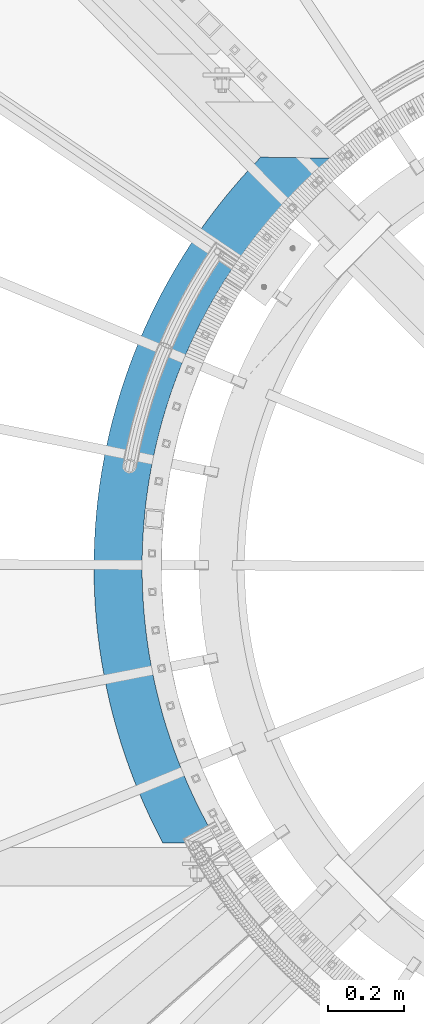
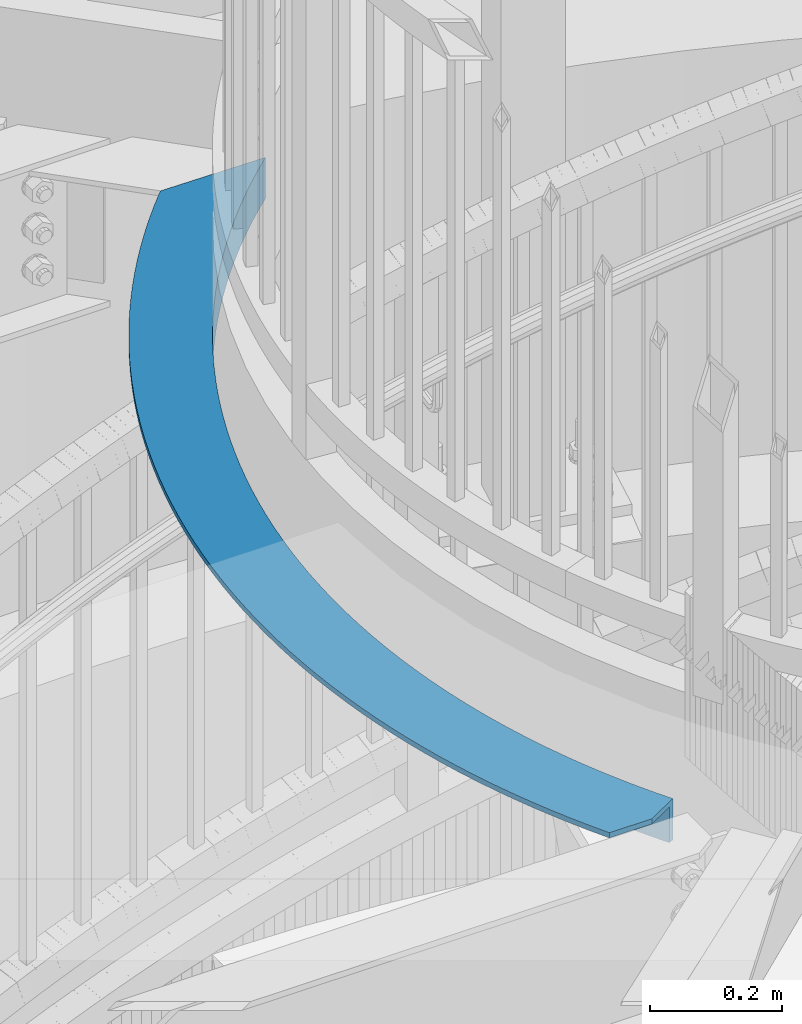
# One storey, part 345 of 975: 1 beam.
"""IFC2X3 building model written with IfcOpenShell, lengths in millimetres."""

from ifc_helpers import new_model, si_unit, frame, origin_with_axes, place, context, subcontext, project, spatial, faceted_brep, material, type_object, element, save


model = new_model("IFC2X3")

# Units and contexts
model_context = context("Model", 3, precision=1e-05, world=origin_with_axes())
body_context = subcontext(model_context, "Body", "Model", "MODEL_VIEW")
ifc_project = project(units=[si_unit("LENGTHUNIT", "METRE", prefix="MILLI"), si_unit("AREAUNIT", "SQUARE_METRE"), si_unit("VOLUMEUNIT", "CUBIC_METRE"), si_unit("MASSUNIT", "GRAM", prefix="KILO"), si_unit("TIMEUNIT", "SECOND"), si_unit("PLANEANGLEUNIT", "RADIAN"), si_unit("SOLIDANGLEUNIT", "STERADIAN"), si_unit("THERMODYNAMICTEMPERATUREUNIT", "DEGREE_CELSIUS"), si_unit("LUMINOUSINTENSITYUNIT", "LUMEN")], contexts=[model_context])

# Site, building, storey
site_placement = place(None, origin_with_axes())
site = spatial("IfcSite", under=ifc_project, at=site_placement, CompositionType="ELEMENT")
building_placement = place(site_placement, origin_with_axes())
building = spatial("IfcBuilding", under=site, at=building_placement, Name="Undefined", CompositionType="ELEMENT")
storey_placement = place(building_placement, origin_with_axes())
storey = spatial("IfcBuildingStorey", under=building, at=storey_placement, Name="Undefined", CompositionType="ELEMENT", Elevation=0.0)

# Beam
ifc_material = material(Name="STEEL/A36")
beam_type = type_object("IfcBeamType", Name="L5X3X3/8", PredefinedType="NOTDEFINED")
beam_placement = place(storey_placement, frame((33766.1698728571, 4529.50299331997, 3898.87411734782), z_axis=(-0.984820230932939, 0.173577396988181, 0.0), x_axis=(-0.173577396988181, -0.984820230932939, 0.0)))
element("IfcBeam", 1, at=beam_placement, inside=storey, type_object=beam_type, material=ifc_material, Name="ANGLE", ObjectType="L5X3X3/8", context=body_context, shape_type="Brep", body=[
    faceted_brep([(66.105245701081, 38.0999999999999, -28.3957364368362), (66.105245701081, -38.0999999999999, -28.3957364368362), (40.2817207764638, -38.0999999999999, -49.0880125008807), (40.2817207764638, 38.0999999999999, -49.0880125008807), (92.4037302386423, 38.0999999999999, -8.31055684413514), (92.4037302386423, -38.0999999999999, -8.31055684413514), (119.162905015355, 38.0999999999999, 11.1566281992309), (119.162905015355, -38.0999999999999, 11.1566281992309), (146.368250690128, 38.0999999999999, 29.995255934813), (146.368250690128, -38.0999999999999, 29.995255934813), (174.00500583266, 38.0999999999999, 48.1951046549366), (174.00500583266, -38.0999999999999, 48.1951046549366), (202.058174932887, 38.0999999999999, 65.7462992489891), (202.058174932887, -38.0999999999999, 65.7462992489891), (230.512536537448, 38.0999999999999, 82.6393165615118), (230.512536537448, -38.0999999999999, 82.6393165615118), (259.352651508736, 38.0999999999999, 98.8649905594502), (259.352651508736, -38.0999999999999, 98.8649905594502), (288.562871402057, 38.0999999999999, 114.41451730558), (288.562871402057, -38.0999999999999, 114.41451730558), (318.12734695638, 38.0999999999999, 129.27945973543), (318.12734695638, -38.0999999999999, 129.27945973543), (348.030036694036, 38.0999999999999, 143.4517522352), (348.030036694036, -38.0999999999999, 143.4517522352), (378.254715624691, 38.0999999999999, 156.923705018093), (378.254715624691, -38.0999999999999, 156.923705018093), (408.784984048936, 38.0999999999999, 169.688008296729), (408.784984048936, -38.0999999999999, 169.688008296729), (439.604276456645, 38.0999999999999, 181.737736249441), (439.604276456645, -38.0999999999999, 181.737736249441), (470.695870515287, 38.0999999999999, 193.066350778106), (470.695870515287, -38.0999999999999, 193.066350778106), (502.042896143366, 38.0999999999999, 203.667705055697), (502.042896143366, -38.0999999999999, 203.667705055697), (533.628344664008, 38.0999999999999, 213.536046861529), (533.628344664008, -38.0999999999999, 213.536046861529), (565.435078033734, 38.0999999999999, 222.666021702353), (565.435078033734, -38.0999999999999, 222.666021702353), (597.445838141466, 38.0999999999999, 231.052675717678), (597.445838141466, -38.0999999999999, 231.052675717678), (629.643256172631, 38.0999999999999, 238.691458367688), (629.643256172631, -38.0999999999999, 238.691458367688), (662.009862033385, 38.0999999999999, 245.578224902321), (662.009862033385, -38.0999999999999, 245.578224902321), (694.528093829738, 38.0999999999999, 251.709238610234), (694.528093829738, -38.0999999999999, 251.709238610234), (727.180307396542, 38.0999999999999, 257.081172846269), (727.180307396542, -38.0999999999999, 257.081172846269), (759.948785871067, 38.0999999999999, 261.691112836466), (759.948785871067, -38.0999999999999, 261.691112836466), (792.815749306061, 38.0999999999999, 265.536557259638), (792.815749306061, -38.0999999999999, 265.536557259638), (825.763364317019, 38.0999999999999, 268.615419604528), (825.763364317019, -38.0999999999999, 268.615419604528), (858.773753758458, 38.0999999999999, 270.926029301954), (858.773753758458, -38.0999999999999, 270.926029301954), (891.829006423926, 38.0999999999999, 272.467132631271), (891.829006423926, -38.0999999999999, 272.467132631271), (924.911186764504, 38.0999999999999, 273.237893400576), (924.911186764504, -38.0999999999999, 273.237893400576), (958.002344620492, 38.0999999999999, 273.237893400463), (958.002344620492, -38.0999999999999, 273.237893400463), (991.084524961068, 38.0999999999999, 272.467132630947), (991.084524961068, -38.0999999999999, 272.467132630947), (1024.13977762654, 38.0999999999999, 270.926029301419), (1024.13977762654, -38.0999999999999, 270.926029301419), (1057.15016706799, 38.0999999999999, 268.615419603779), (1057.15016706799, -38.0999999999999, 268.615419603779), (1090.09778207895, 38.0999999999999, 265.536557258671), (1090.09778207895, -38.0999999999999, 265.536557258671), (1122.96474551395, 38.0999999999999, 261.691112835284), (1122.96474551395, -38.0999999999999, 261.691112835284), (1155.73322398849, 38.0999999999999, 257.081172844868), (1155.73322398849, -38.0999999999999, 257.081172844868), (1188.3854375553, 38.0999999999999, 251.709238608633), (1188.3854375553, -38.0999999999999, 251.709238608633), (1220.90366935167, 38.0999999999999, 245.57822490051), (1220.90366935167, -38.0999999999999, 245.57822490051), (1253.27027521243, 38.0999999999999, 238.691458365654), (1253.27027521243, -38.0999999999999, 238.691458365654), (1285.46769324361, 38.0999999999999, 231.05267571544), (1285.46769324361, -38.0999999999999, 231.05267571544), (1317.47845335136, 38.0999999999999, 222.666021699915), (1317.47845335136, -38.0999999999999, 222.666021699915), (1349.2851867211, 38.0999999999999, 213.536046858881), (1349.2851867211, -38.0999999999999, 213.536046858881), (1380.87063524176, 38.0999999999999, 203.667705052841), (1380.87063524176, -38.0999999999999, 203.667705052841), (1412.21766086986, 38.0999999999999, 193.066350775036), (1412.21766086986, -38.0999999999999, 193.066350775036), (1443.30925492853, 38.0999999999999, 181.737736246178), (1443.30925492853, -38.0999999999999, 181.737736246178), (1474.12854733626, 38.0999999999999, 169.688008293273), (1474.12854733626, -38.0999999999999, 169.688008293273), (1504.65881576053, 38.0999999999999, 156.923705014426), (1504.65881576053, -38.0999999999999, 156.923705014426), (1534.88349469121, 38.0999999999999, 143.451752231344), (1534.88349469121, -38.0999999999999, 143.451752231344), (1564.78618442889, 38.0999999999999, 129.279459731377), (1564.78618442889, -38.0999999999999, 129.279459731377), (1594.35065998325, 38.0999999999999, 114.414517301338), (1594.35065998325, -38.0999999999999, 114.414517301338), (1623.5608798766, 38.0999999999999, 98.8649905550119), (1623.5608798766, -38.0999999999999, 98.8649905550119), (1652.40099484791, 38.0999999999999, 82.6393165568843), (1652.40099484791, -38.0999999999999, 82.6393165568843), (1680.85535645251, 38.0999999999999, 65.746299244176), (1680.85535645251, -38.0999999999999, 65.746299244176), (1708.90852555277, 38.0999999999999, 48.1951046499489), (1708.90852555277, -38.0999999999999, 48.1951046499489), (1736.54528069534, 38.0999999999999, 29.9952559296398), (1736.54528069534, -38.0999999999999, 29.9952559296398), (1763.75062637015, 38.0999999999999, 11.1566281938867), (1763.75062637015, -38.0999999999999, 11.1566281938867), (1790.5098011469, 38.0999999999999, -8.31055684965759), (1790.5098011469, -38.0999999999999, -8.31055684965759), (1816.8082856845, 38.0999999999999, -28.3957364425223), (1816.8082856845, -38.0999999999999, -28.3957364425223), (1842.63181060915, 38.0999999999999, -49.0880125067415), (1842.63181060915, -38.0999999999999, -49.0880125067415), (1848.67406872561, -38.0999999999999, -41.7248106316438), (1822.67740052102, -38.0999999999999, -20.8937956246518), (1796.20258816282, -38.0999999999999, -0.673947589606541), (1769.26399669905, -38.0999999999999, 18.9237623253139), (1741.87624282104, -38.0999999999999, 37.8887005397955), (1714.0541869325, -38.0999999999999, 56.2105768109832), (1685.81292508639, -38.0999999999999, 73.8794498169664), (1657.16778079388, -38.0999999999999, 90.8857325507997), (1628.13429670992, -38.0999999999999, 107.220197522402), (1598.72822619994, -38.0999999999999, 122.873981765326), (1568.96552479215, -38.0999999999999, 137.83859164573), (1538.86234152018, -38.0999999999999, 152.105907470926), (1508.43501016074, -38.0999999999999, 165.668187895139), (1477.70004037104, -38.0999999999999, 178.518074119842), (1446.67410873074, -38.0999999999999, 190.648593886661), (1415.37404969336, -38.0999999999999, 202.053165260393), (1383.81684645205, -38.0999999999999, 212.725600200367), (1352.01962172458, -38.0999999999999, 222.660107918018), (1319.99962846271, -38.0999999999999, 231.851298018955), (1287.77424049086, -38.0999999999999, 240.294183427686), (1255.36094307917, -38.0999999999999, 247.984183093642), (1222.77732345613, -38.0999999999999, 254.917124476797), (1190.04106126587, -38.0999999999999, 261.089245811625), (1157.16991897533, -38.0999999999999, 266.497198148263), (1124.18173223641, -38.0999999999999, 271.138047169592), (1091.09440020853, -38.0999999999999, 275.009274783381), (1057.92587584667, -38.0999999999999, 278.108780488619), (1024.69415616017, -38.0999999999999, 280.434882515183), (991.417272447727, -38.0999999999999, 281.986318736363), (958.113280513719, -38.0999999999999, 282.76224735373), (924.800250871258, -38.0999999999999, 282.762247353832), (891.496258937252, -38.0999999999999, 281.986318736679), (858.219375224813, -38.0999999999999, 280.434882515718), (824.987655538316, -38.0999999999999, 278.10878048938), (791.819131176459, -38.0999999999999, 275.009274784359), (758.731799148594, -38.0999999999999, 271.138047170782), (725.743612409682, -38.0999999999999, 266.497198149664), (692.872470119144, -38.0999999999999, 261.08924581324), (660.136207928903, -38.0999999999999, 254.917124478627), (627.552588305876, -38.0999999999999, 247.984183095683), (595.1392908942, -38.0999999999999, 240.294183429934), (562.913902922366, -38.0999999999999, 231.851298021411), (530.893909660517, -38.0999999999999, 222.660107920692), (499.096684933063, -38.0999999999999, 212.725600203237), (467.539481691769, -38.0999999999999, 202.053165263467), (436.239422654415, -38.0999999999999, 190.648593889946), (405.213491014136, -38.0999999999999, 178.518074123331), (374.478521224461, -38.0999999999999, 165.668187898817), (344.051189865051, -38.0999999999999, 152.105907474808), (313.948006593106, -38.0999999999999, 137.838591649808), (284.18530518534, -38.0999999999999, 122.873981769608), (254.779234675394, -38.0999999999999, 107.220197526869), (225.745750591472, -38.0999999999999, 90.8857325554491), (197.100606298991, -38.0999999999999, 73.8794498217976), (168.859344452916, -38.0999999999999, 56.2105768160181), (141.037288564414, -38.0999999999999, 37.8887005449978), (113.649534686439, -38.0999999999999, 18.9237623306944), (86.7109432227044, -38.0999999999999, -0.673947584058624), (60.236130864545, -38.0999999999999, -20.8937956189184), (42.5515561670727, -38.0999999999999, -35.064366940358), (1822.67740052102, 28.5749999999998, -20.8937956246518), (1848.67406872561, 28.5749999999998, -41.7248106316438), (1796.20258816282, 28.5749999999998, -0.673947589606541), (1769.26399669905, 28.5749999999998, 18.9237623253139), (1741.87624282104, 28.5749999999998, 37.8887005397955), (1714.0541869325, 28.5749999999998, 56.2105768109832), (1685.81292508639, 28.5749999999998, 73.8794498169664), (1657.16778079388, 28.5749999999998, 90.8857325507997), (1628.13429670992, 28.5749999999998, 107.220197522402), (1598.72822619994, 28.5749999999998, 122.873981765326), (1568.96552479215, 28.5749999999998, 137.83859164573), (1538.86234152018, 28.5749999999998, 152.105907470926), (1508.43501016074, 28.5749999999998, 165.668187895139), (1477.70004037104, 28.5749999999998, 178.518074119842), (1446.67410873074, 28.5749999999998, 190.648593886661), (1415.37404969336, 28.5749999999998, 202.053165260393), (1383.81684645205, 28.5749999999998, 212.725600200367), (1352.01962172458, 28.5749999999998, 222.660107918018), (1319.99962846271, 28.5749999999998, 231.851298018955), (1287.77424049086, 28.5749999999998, 240.294183427686), (1255.36094307917, 28.5749999999998, 247.984183093642), (1222.77732345613, 28.5749999999998, 254.917124476797), (1190.04106126587, 28.5749999999998, 261.089245811625), (1157.16991897533, 28.5749999999998, 266.497198148263), (1124.18173223641, 28.5749999999998, 271.138047169592), (1091.09440020853, 28.5749999999998, 275.009274783381), (1057.92587584667, 28.5749999999998, 278.108780488619), (1024.69415616017, 28.5749999999998, 280.434882515183), (991.417272447727, 28.5749999999998, 281.986318736363), (958.113280513719, 28.5749999999998, 282.76224735373), (924.800250871258, 28.5749999999998, 282.762247353832), (891.496258937252, 28.5749999999998, 281.986318736679), (858.219375224813, 28.5749999999998, 280.434882515718), (824.987655538316, 28.5749999999998, 278.10878048938), (791.819131176459, 28.5749999999998, 275.009274784359), (758.731799148594, 28.5749999999998, 271.138047170782), (725.743612409682, 28.5749999999998, 266.497198149664), (692.872470119144, 28.5749999999998, 261.08924581324), (660.136207928903, 28.5749999999998, 254.917124478627), (627.552588305876, 28.5749999999998, 247.984183095683), (595.1392908942, 28.5749999999998, 240.294183429934), (562.913902922366, 28.5749999999998, 231.851298021411), (530.893909660517, 28.5749999999998, 222.660107920692), (499.096684933063, 28.5749999999998, 212.725600203237), (467.539481691769, 28.5749999999998, 202.053165263467), (436.239422654415, 28.5749999999998, 190.648593889946), (405.213491014136, 28.5749999999998, 178.518074123331), (374.478521224461, 28.5749999999998, 165.668187898817), (344.051189865051, 28.5749999999998, 152.105907474808), (313.948006593106, 28.5749999999998, 137.838591649808), (284.18530518534, 28.5749999999998, 122.873981769608), (254.779234675394, 28.5749999999998, 107.220197526869), (225.745750591472, 28.5749999999998, 90.8857325554491), (197.100606298991, 28.5749999999998, 73.8794498217976), (168.859344452916, 28.5749999999998, 56.2105768160181), (141.037288564414, 28.5749999999998, 37.8887005449978), (113.649534686439, 28.5749999999998, 18.9237623306944), (86.7109432227044, 28.5749999999998, -0.673947584058624), (60.236130864545, 28.5749999999998, -20.8937956189184), (42.5515561670727, 28.5749999999998, -35.064366940358), (69.4639850216336, 28.5749999999998, 131.207760367786), (69.4639850216336, 38.0999999999999, 131.207760367786), (75.2887556806072, 28.5749999999998, 135.241184070659), (75.2887556806072, 38.0999999999999, 135.241184070659), (105.396187436074, 28.5749999999998, 155.068066802556), (105.396187436074, 38.0999999999999, 155.068066802556), (135.95725981428, 28.5749999999998, 174.188306886528), (135.95725981428, 38.0999999999999, 174.188306886528), (166.955390591085, 28.5749999999998, 192.591529814024), (166.955390591085, 38.0999999999999, 192.591529814024), (198.373760397515, 28.5749999999998, 210.267750124996), (198.373760397515, 38.0999999999999, 210.267750124996), (230.195321845837, 28.5749999999998, 227.207376825903), (230.195321845837, 38.0999999999999, 227.207376825903), (262.402808779359, 28.5749999999998, 243.401218593772), (262.402808779359, 38.0999999999999, 243.401218593772), (294.97874564091, 28.5749999999998, 258.840488763326), (294.97874564091, 38.0999999999999, 258.840488763326), (327.905456954973, 28.5749999999998, 273.51681009453), (327.905456954973, 38.0999999999999, 273.51681009453), (361.165076918263, 28.5749999999998, 287.422219318079), (361.165076918263, 38.0999999999999, 287.422219318079), (394.73955909359, 28.5749999999998, 300.549171456172), (394.73955909359, 38.0999999999999, 300.549171456172), (428.61068620173, 28.5749999999998, 312.890543916372), (428.61068620173, 38.0999999999999, 312.890543916372), (462.760080005994, 28.5749999999998, 324.439640356319), (462.760080005994, 38.0999999999999, 324.439640356319), (497.169211284127, 28.5749999999998, 335.190194317031), (497.169211284127, 38.0999999999999, 335.190194317031), (531.81940988214, 28.5749999999998, 345.136372623117), (531.81940988214, 38.0999999999999, 345.136372623117), (566.691874844604, 28.5749999999998, 354.272778547795), (566.691874844604, 38.0999999999999, 354.272778547795), (601.767684615908, 28.5749999999998, 362.594454741102), (601.767684615908, 38.0999999999999, 362.594454741102), (637.027807306975, 28.5749999999998, 370.096885919727), (637.027807306975, 38.0999999999999, 370.096885919727), (672.45311102183, 28.5749999999998, 376.776001316997), (672.45311102183, 38.0999999999999, 376.776001316997), (708.024374238419, 28.5749999999998, 382.628176891587), (708.024374238419, 38.0999999999999, 382.628176891587), (743.722296238095, 28.5749999999998, 387.650237293972), (743.722296238095, 38.0999999999999, 387.650237293972), (779.527507578034, 28.5749999999998, 391.8394575893), (779.527507578034, 38.0999999999999, 391.8394575893), (815.420580600969, 28.5749999999998, 395.193564735928), (815.420580600969, 38.0999999999999, 395.193564735928), (851.382039976495, 28.5749999999998, 397.710738818783), (851.382039976495, 38.0999999999999, 397.710738818783), (887.392373268254, 28.5749999999998, 399.389614036809), (887.392373268254, 38.0999999999999, 399.389614036809), (923.432041521242, 28.5749999999998, 400.229279444047), (923.432041521242, 38.0999999999999, 400.229279444047), (959.481489863509, 28.5749999999998, 400.229279443931), (959.481489863509, 38.0999999999999, 400.229279443931), (995.521158116499, 28.5749999999998, 399.389614036449), (995.521158116499, 38.0999999999999, 399.389614036449), (1031.53149140826, 28.5749999999998, 397.710738818201), (1031.53149140826, 38.0999999999999, 397.710738818201), (1067.49295078379, 28.5749999999998, 395.193564735106), (1067.49295078379, 38.0999999999999, 395.193564735106), (1103.38602380673, 28.5749999999998, 391.839457588248), (1103.38602380673, 38.0999999999999, 391.839457588248), (1139.19123514668, 28.5749999999998, 387.650237292688), (1139.19123514668, 38.0999999999999, 387.650237292688), (1174.88915714636, 28.5749999999998, 382.628176890074), (1174.88915714636, 38.0999999999999, 382.628176890074), (1210.46042036297, 28.5749999999998, 376.776001315247), (1210.46042036297, 38.0999999999999, 376.776001315247), (1245.88572407783, 28.5749999999998, 370.096885917748), (1245.88572407783, 38.0999999999999, 370.096885917748), (1281.14584676892, 28.5749999999998, 362.594454738894), (1281.14584676892, 38.0999999999999, 362.594454738894), (1316.22165654024, 28.5749999999998, 354.272778545361), (1316.22165654024, 38.0999999999999, 354.272778545361), (1351.09412150272, 28.5749999999998, 345.136372620458), (1351.09412150272, 38.0999999999999, 345.136372620458), (1385.74432010075, 28.5749999999998, 335.190194314138), (1385.74432010075, 38.0999999999999, 335.190194314138), (1420.1534513789, 28.5749999999998, 324.439640353201), (1420.1534513789, 38.0999999999999, 324.439640353201), (1454.30284518319, 28.5749999999998, 312.890543913043), (1454.30284518319, 38.0999999999999, 312.890543913043), (1488.17397229135, 28.5749999999998, 300.549171452611), (1488.17397229135, 38.0999999999999, 300.549171452611), (1521.74845446671, 28.5749999999998, 287.422219314307), (1521.74845446671, 38.0999999999999, 287.422219314307), (1555.00807443002, 28.5749999999998, 273.516810090543), (1555.00807443002, 38.0999999999999, 273.516810090543), (1587.93478574411, 28.5749999999998, 258.84048875912), (1587.93478574411, 38.0999999999999, 258.84048875912), (1620.51072260569, 28.5749999999998, 243.401218589359), (1620.51072260569, 38.0999999999999, 243.401218589359), (1652.71820953925, 28.5749999999998, 227.207376821272), (1652.71820953925, 38.0999999999999, 227.207376821272), (1684.5397709876, 28.5749999999998, 210.267750120162), (1684.5397709876, 38.0999999999999, 210.267750120162), (1715.95814079407, 28.5749999999998, 192.591529808989), (1715.95814079407, 38.0999999999999, 192.591529808989), (1746.95627157091, 28.5749999999998, 174.1883068813), (1746.95627157091, 38.0999999999999, 174.1883068813), (1777.51734394915, 28.5749999999998, 155.068066797121), (1777.51734394915, 38.0999999999999, 155.068066797121), (1807.62477570465, 28.5749999999998, 135.241184065031), (1807.62477570465, 38.0999999999999, 135.241184065031), (1837.26223075551, 28.5749999999998, 114.718416612919), (1837.26223075551, 38.0999999999999, 114.718416612919), (1866.41362802587, 28.5749999999998, 93.510899950903), (1866.41362802587, 38.0999999999999, 93.510899950903), (1894.81293557287, 28.5749999999998, 71.821239788962), (1894.81293557287, 38.0999999999999, 71.821239788962), (1881.94682932637, 38.0999999999999, -1.1780401158685), (1881.94682932637, 28.5749999999998, -1.1780401158685)], [[[0, 1, 2, 3]], [[1, 0, 4, 5]], [[5, 4, 6, 7]], [[7, 6, 8, 9]], [[9, 8, 10, 11]], [[11, 10, 12, 13]], [[13, 12, 14, 15]], [[15, 14, 16, 17]], [[17, 16, 18, 19]], [[19, 18, 20, 21]], [[21, 20, 22, 23]], [[23, 22, 24, 25]], [[25, 24, 26, 27]], [[27, 26, 28, 29]], [[29, 28, 30, 31]], [[31, 30, 32, 33]], [[33, 32, 34, 35]], [[35, 34, 36, 37]], [[37, 36, 38, 39]], [[39, 38, 40, 41]], [[41, 40, 42, 43]], [[43, 42, 44, 45]], [[45, 44, 46, 47]], [[47, 46, 48, 49]], [[49, 48, 50, 51]], [[51, 50, 52, 53]], [[53, 52, 54, 55]], [[55, 54, 56, 57]], [[57, 56, 58, 59]], [[59, 58, 60, 61]], [[61, 60, 62, 63]], [[63, 62, 64, 65]], [[65, 64, 66, 67]], [[67, 66, 68, 69]], [[69, 68, 70, 71]], [[71, 70, 72, 73]], [[73, 72, 74, 75]], [[75, 74, 76, 77]], [[77, 76, 78, 79]], [[79, 78, 80, 81]], [[81, 80, 82, 83]], [[83, 82, 84, 85]], [[85, 84, 86, 87]], [[87, 86, 88, 89]], [[89, 88, 90, 91]], [[91, 90, 92, 93]], [[93, 92, 94, 95]], [[95, 94, 96, 97]], [[97, 96, 98, 99]], [[99, 98, 100, 101]], [[101, 100, 102, 103]], [[103, 102, 104, 105]], [[105, 104, 106, 107]], [[107, 106, 108, 109]], [[109, 108, 110, 111]], [[111, 110, 112, 113]], [[113, 112, 114, 115]], [[115, 114, 116, 117]], [[117, 116, 118, 119]], [[1, 5, 7, 9, 11, 13, 15, 17, 19, 21, 23, 25, 27, 29, 31, 33, 35, 37, 39, 41, 43, 45, 47, 49, 51, 53, 55, 57, 59, 61, 63, 65, 67, 69, 71, 73, 75, 77, 79, 81, 83, 85, 87, 89, 91, 93, 95, 97, 99, 101, 103, 105, 107, 109, 111, 113, 115, 117, 119, 120, 121, 122, 123, 124, 125, 126, 127, 128, 129, 130, 131, 132, 133, 134, 135, 136, 137, 138, 139, 140, 141, 142, 143, 144, 145, 146, 147, 148, 149, 150, 151, 152, 153, 154, 155, 156, 157, 158, 159, 160, 161, 162, 163, 164, 165, 166, 167, 168, 169, 170, 171, 172, 173, 174, 175, 176, 177, 178, 179, 2]], [[180, 121, 120, 181]], [[182, 122, 121, 180]], [[183, 123, 122, 182]], [[184, 124, 123, 183]], [[185, 125, 124, 184]], [[186, 126, 125, 185]], [[187, 127, 126, 186]], [[188, 128, 127, 187]], [[189, 129, 128, 188]], [[190, 130, 129, 189]], [[191, 131, 130, 190]], [[192, 132, 131, 191]], [[193, 133, 132, 192]], [[194, 134, 133, 193]], [[195, 135, 134, 194]], [[196, 136, 135, 195]], [[197, 137, 136, 196]], [[198, 138, 137, 197]], [[199, 139, 138, 198]], [[200, 140, 139, 199]], [[201, 141, 140, 200]], [[202, 142, 141, 201]], [[203, 143, 142, 202]], [[204, 144, 143, 203]], [[205, 145, 144, 204]], [[206, 146, 145, 205]], [[207, 147, 146, 206]], [[208, 148, 147, 207]], [[209, 149, 148, 208]], [[210, 150, 149, 209]], [[211, 151, 150, 210]], [[212, 152, 151, 211]], [[213, 153, 152, 212]], [[214, 154, 153, 213]], [[215, 155, 154, 214]], [[216, 156, 155, 215]], [[217, 157, 156, 216]], [[218, 158, 157, 217]], [[219, 159, 158, 218]], [[220, 160, 159, 219]], [[221, 161, 160, 220]], [[222, 162, 161, 221]], [[223, 163, 162, 222]], [[224, 164, 163, 223]], [[225, 165, 164, 224]], [[226, 166, 165, 225]], [[227, 167, 166, 226]], [[228, 168, 167, 227]], [[229, 169, 168, 228]], [[230, 170, 169, 229]], [[231, 171, 170, 230]], [[232, 172, 171, 231]], [[233, 173, 172, 232]], [[234, 174, 173, 233]], [[235, 175, 174, 234]], [[236, 176, 175, 235]], [[237, 177, 176, 236]], [[238, 178, 177, 237]], [[178, 238, 239, 179]], [[3, 2, 179, 239, 240, 241]], [[242, 243, 241, 240]], [[243, 242, 244, 245]], [[245, 244, 246, 247]], [[247, 246, 248, 249]], [[249, 248, 250, 251]], [[251, 250, 252, 253]], [[253, 252, 254, 255]], [[255, 254, 256, 257]], [[257, 256, 258, 259]], [[259, 258, 260, 261]], [[261, 260, 262, 263]], [[263, 262, 264, 265]], [[265, 264, 266, 267]], [[267, 266, 268, 269]], [[269, 268, 270, 271]], [[271, 270, 272, 273]], [[273, 272, 274, 275]], [[275, 274, 276, 277]], [[277, 276, 278, 279]], [[279, 278, 280, 281]], [[281, 280, 282, 283]], [[283, 282, 284, 285]], [[285, 284, 286, 287]], [[287, 286, 288, 289]], [[289, 288, 290, 291]], [[291, 290, 292, 293]], [[293, 292, 294, 295]], [[295, 294, 296, 297]], [[297, 296, 298, 299]], [[299, 298, 300, 301]], [[301, 300, 302, 303]], [[303, 302, 304, 305]], [[305, 304, 306, 307]], [[307, 306, 308, 309]], [[309, 308, 310, 311]], [[311, 310, 312, 313]], [[313, 312, 314, 315]], [[315, 314, 316, 317]], [[317, 316, 318, 319]], [[319, 318, 320, 321]], [[321, 320, 322, 323]], [[323, 322, 324, 325]], [[325, 324, 326, 327]], [[327, 326, 328, 329]], [[329, 328, 330, 331]], [[331, 330, 332, 333]], [[333, 332, 334, 335]], [[335, 334, 336, 337]], [[337, 336, 338, 339]], [[339, 338, 340, 341]], [[341, 340, 342, 343]], [[343, 342, 344, 345]], [[345, 344, 346, 347]], [[347, 346, 348, 349]], [[349, 348, 350, 351]], [[118, 116, 114, 112, 110, 108, 106, 104, 102, 100, 98, 96, 94, 92, 90, 88, 86, 84, 82, 80, 78, 76, 74, 72, 70, 68, 66, 64, 62, 60, 58, 56, 54, 52, 50, 48, 46, 44, 42, 40, 38, 36, 34, 32, 30, 28, 26, 24, 22, 20, 18, 16, 14, 12, 10, 8, 6, 4, 0, 3, 241, 243, 245, 247, 249, 251, 253, 255, 257, 259, 261, 263, 265, 267, 269, 271, 273, 275, 277, 279, 281, 283, 285, 287, 289, 291, 293, 295, 297, 299, 301, 303, 305, 307, 309, 311, 313, 315, 317, 319, 321, 323, 325, 327, 329, 331, 333, 335, 337, 339, 341, 343, 345, 347, 349, 351, 352]], [[181, 120, 119, 118, 352, 353]], [[348, 346, 344, 342, 340, 338, 336, 334, 332, 330, 328, 326, 324, 322, 320, 318, 316, 314, 312, 310, 308, 306, 304, 302, 300, 298, 296, 294, 292, 290, 288, 286, 284, 282, 280, 278, 276, 274, 272, 270, 268, 266, 264, 262, 260, 258, 256, 254, 252, 250, 248, 246, 244, 242, 240, 239, 238, 237, 236, 235, 234, 233, 232, 231, 230, 229, 228, 227, 226, 225, 224, 223, 222, 221, 220, 219, 218, 217, 216, 215, 214, 213, 212, 211, 210, 209, 208, 207, 206, 205, 204, 203, 202, 201, 200, 199, 198, 197, 196, 195, 194, 193, 192, 191, 190, 189, 188, 187, 186, 185, 184, 183, 182, 180, 181, 353, 350]], [[352, 351, 350, 353]]]),
])

save(model, "model.ifc")
